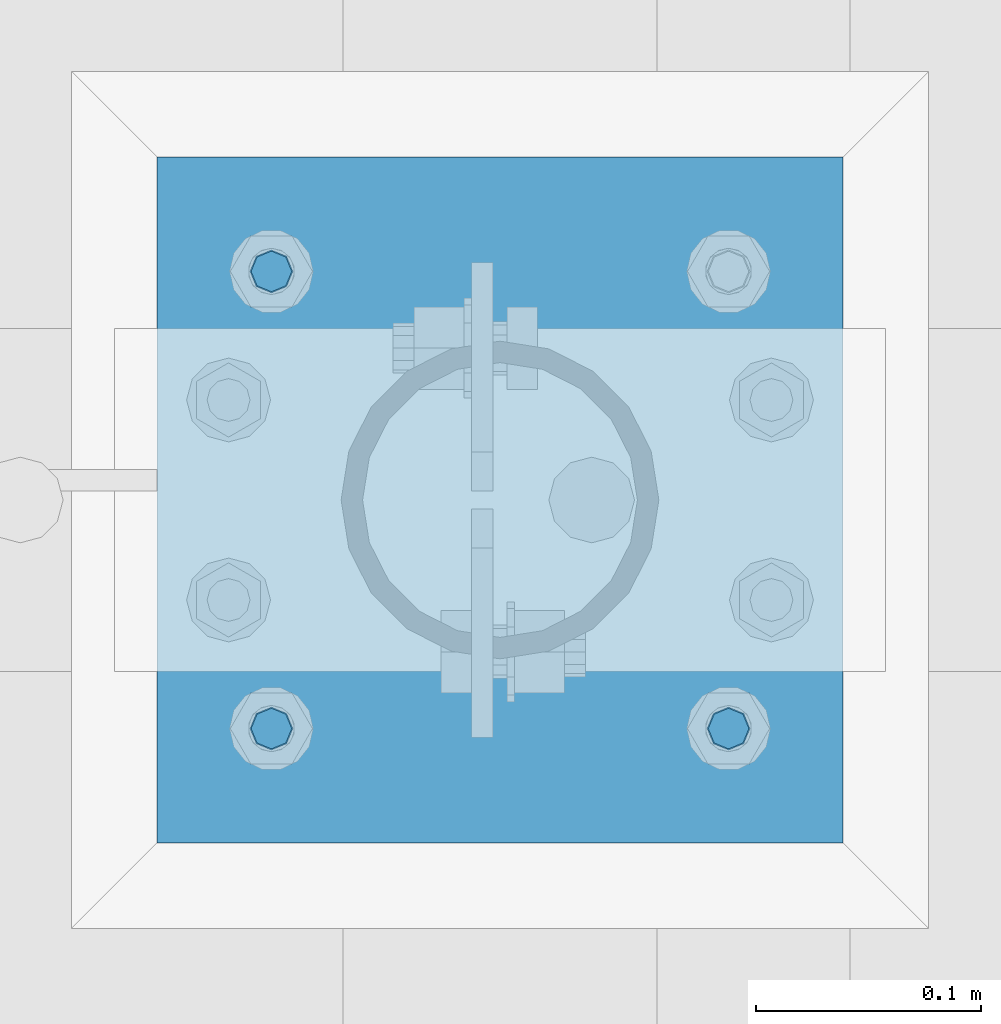
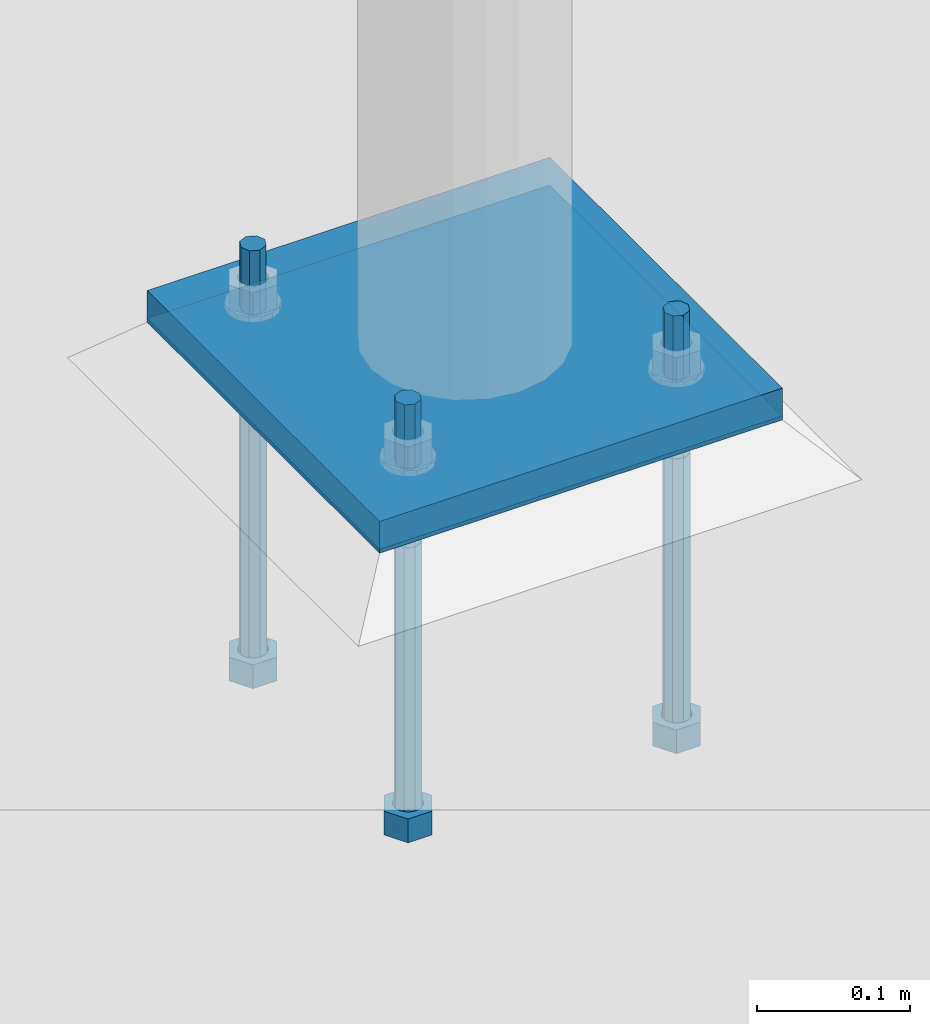
# One storey, part 399 of 975: 5 beams.
"""IFC2X3 building model written with IfcOpenShell, lengths in millimetres."""

from ifc_helpers import new_model, si_unit, frame, origin_with_axes, place, context, subcontext, project, spatial, faceted_brep, material, type_object, element, save


model = new_model("IFC2X3")

# Units and contexts
model_context = context("Model", 3, precision=1e-05, world=origin_with_axes())
body_context = subcontext(model_context, "Body", "Model", "MODEL_VIEW")
ifc_project = project(units=[si_unit("LENGTHUNIT", "METRE", prefix="MILLI"), si_unit("AREAUNIT", "SQUARE_METRE"), si_unit("VOLUMEUNIT", "CUBIC_METRE"), si_unit("MASSUNIT", "GRAM", prefix="KILO"), si_unit("TIMEUNIT", "SECOND"), si_unit("PLANEANGLEUNIT", "RADIAN"), si_unit("SOLIDANGLEUNIT", "STERADIAN"), si_unit("THERMODYNAMICTEMPERATUREUNIT", "DEGREE_CELSIUS"), si_unit("LUMINOUSINTENSITYUNIT", "LUMEN")], contexts=[model_context])

# Site, building, storey
site_placement = place(None, origin_with_axes())
site = spatial("IfcSite", under=ifc_project, at=site_placement, CompositionType="ELEMENT")
building_placement = place(site_placement, origin_with_axes())
building = spatial("IfcBuilding", under=site, at=building_placement, Name="Undefined", CompositionType="ELEMENT")
storey_placement = place(building_placement, origin_with_axes())
storey = spatial("IfcBuildingStorey", under=building, at=storey_placement, Name="Undefined", CompositionType="ELEMENT", Elevation=0.0)

# Beams
ifc_material_1 = material(Name="STEEL/F1554-36")
beam_type_1 = type_object("IfcBeamType", PredefinedType="NOTDEFINED")
beam_1_placement = place(storey_placement, frame((8128.00000152588, 13493.75, -304.799999999999), z_axis=(0.0, -1.0, 0.0), x_axis=(0.0, 0.0, -1.0)))
element("IfcBeam", 1, at=beam_1_placement, inside=storey, type_object=beam_type_1, material=ifc_material_1, Name="HEADED_ANCHOR_BOLT", context=body_context, shape_type="Brep", body=[
    faceted_brep([(210.34375, -9.13000011444637, 15.8100004196167), (210.34375, -18.2600002288873, 0.0), (229.393749999999, -18.2600002288873, 0.0), (229.393749999999, -9.13000011444637, 15.8100004196167), (210.34375, 9.13000011443546, 15.8100004196167), (229.393749999999, 9.13000011443546, 15.8100004196167), (210.34375, 18.2600002288764, 0.0), (229.393749999999, 18.2600002288764, 0.0), (210.34375, 9.13000011443546, -15.8100004196167), (229.393749999999, 9.13000011443546, -15.8100004196167), (210.34375, -9.13000011444637, -15.8100004196167), (229.393749999999, -9.13000011444637, -15.8100004196167), (210.34375, -4.47768005528815, 9.29799844179888), (210.34375, -8.06850066047991, 6.43441456490837), (210.34375, -10.0612557561972, 2.29641597052159), (210.34375, -10.0612557561972, -2.29641597052159), (210.34375, -8.06850066047991, -6.43441456490837), (210.34375, -4.47768005528815, -9.29799844179888), (210.34375, -5.45696821063757e-12, -10.3199996948242), (210.34375, 4.47768005527723, -9.29799844179888), (210.34375, 8.068500660469, -6.43441456490837), (210.34375, 10.0612557561863, -2.29641597052159), (210.34375, 10.0612557561863, 2.29641597052159), (210.34375, 8.068500660469, 6.43441456490837), (210.34375, 4.47768005527723, 9.29799844179888), (210.34375, -5.45696821063757e-12, 10.3199996948242), (229.393749999999, -5.45696821063757e-12, 10.3199996948242), (229.393749999999, -4.47768005528815, 9.29799844179888), (229.393749999999, -8.06850066047991, 6.43441456490837), (229.393749999999, -10.0612557561972, 2.29641597052159), (229.393749999999, -10.0612557561972, -2.29641597052159), (229.393749999999, -8.06850066047991, -6.43441456490837), (229.393749999999, -4.47768005528815, -9.29799844179888), (229.393749999999, -5.45696821063757e-12, -10.3199996948242), (229.393749999999, 4.47768005527723, -9.29799844179888), (229.393749999999, 8.068500660469, -6.43441456490837), (229.393749999999, 10.0612557561863, -2.29641597052159), (229.393749999999, 10.0612557561863, 2.29641597052159), (229.393749999999, 8.068500660469, 6.43441456490837), (229.393749999999, 4.47768005527723, 9.29799844179888), (0.0, -6.73519209080223, 6.73519209080186), (0.0, -9.52499999999964, 0.0), (228.6, -9.52500000000146, 0.0), (228.6, -6.73519209080405, 6.73519209080223), (-9.87109982941227e-13, -1.20792265079217e-13, 9.52499961853027), (228.6, 0.0, 9.52499999999964), (0.0, 6.73519209080223, 6.73519209080186), (228.6, 6.73519209080405, 6.73519209080223), (0.0, 9.52499999999964, 0.0), (228.6, 9.52500000000146, 0.0), (0.0, 6.73519209080223, -6.73519209080186), (228.6, 6.73519209080405, -6.73519209080223), (2.95075507493764e-12, -1.20792265079217e-13, -9.52499961853027), (228.6, 0.0, -9.52499999999964), (-114.293750057273, -6.36396001342564, 6.36396103067909), (-114.293749999997, 1.01725345302839e-06, 9.0), (-114.293749942721, 6.36396204793255, 6.36396103067909), (-114.293749918997, 9.00000101725345, 0.0), (-114.293749942721, 6.36396204793255, -6.36396103067909), (-114.293749999997, 1.01725345302839e-06, -9.0), (-114.293750057273, -6.36396001342564, -6.36396103067909), (-114.293750080997, -8.99999898274655, 0.0), (0.00625005727778216, 6.36396101919127, -6.36396103067909), (0.00625000000218279, -1.14878275780939e-08, -9.0), (0.00624994272658341, -6.36396104216692, -6.36396103067909), (0.00624991900230043, -9.00000001148783, 0.0), (0.00624994272658341, -6.36396104216692, 6.36396103067909), (0.00625000000218279, -1.14878275780939e-08, 9.0), (0.00625005727778216, 6.36396101919127, 6.36396103067909), (0.00625008100212199, 8.99999998851217, 0.0), (0.0, -6.73519209080223, -6.73519209080186), (228.6, -6.73519209080405, -6.73519209080223)], [[[0, 1, 2, 3]], [[4, 0, 3, 5]], [[6, 4, 5, 7]], [[8, 6, 7, 9]], [[10, 8, 9, 11]], [[0, 4, 6, 8, 10, 1], [12, 13, 14, 15, 16, 17, 18, 19, 20, 21, 22, 23, 24, 25]], [[12, 25, 26, 27]], [[13, 12, 27, 28]], [[14, 13, 28, 29]], [[15, 14, 29, 30]], [[16, 15, 30, 31]], [[17, 16, 31, 32]], [[18, 17, 32, 33]], [[19, 18, 33, 34]], [[20, 19, 34, 35]], [[21, 20, 35, 36]], [[22, 21, 36, 37]], [[23, 22, 37, 38]], [[24, 23, 38, 39]], [[25, 24, 39, 26]], [[9, 7, 5, 3, 2, 11], [38, 37, 36, 35, 34, 33, 32, 31, 30, 29, 28, 27, 26, 39]], [[1, 10, 11, 2]], [[40, 41, 42, 43]], [[44, 40, 43, 45]], [[46, 44, 45, 47]], [[48, 46, 47, 49]], [[50, 48, 49, 51]], [[52, 50, 51, 53]], [[54, 55, 56, 57, 58, 59, 60, 61]], [[59, 58, 62, 63]], [[60, 59, 63, 64]], [[61, 60, 64, 65]], [[54, 61, 65, 66]], [[55, 54, 66, 67]], [[56, 55, 67, 68]], [[57, 56, 68, 69]], [[58, 57, 69, 62]], [[40, 44, 46, 48, 50, 52, 70, 41], [68, 67, 66, 65, 64, 63, 62, 69]], [[41, 70, 71, 42]], [[53, 51, 49, 47, 45, 43, 42, 71]], [[70, 52, 53, 71]]]),
])
beam_2_placement = place(storey_placement, frame((8128.00000152588, 13290.5500030518, -304.799999999999), z_axis=(0.0, -1.0, 0.0), x_axis=(0.0, 0.0, -1.0)))
element("IfcBeam", 2, at=beam_2_placement, inside=storey, type_object=beam_type_1, material=ifc_material_1, Name="HEADED_ANCHOR_BOLT", context=body_context, shape_type="Brep", body=[
    faceted_brep([(210.34375, -9.13000011444637, 15.8100004196167), (210.34375, -18.2600002288873, 0.0), (229.393749999999, -18.2600002288873, 0.0), (229.393749999999, -9.13000011444637, 15.8100004196167), (210.34375, 9.13000011443546, 15.8100004196167), (229.393749999999, 9.13000011443546, 15.8100004196167), (210.34375, 18.2600002288764, 0.0), (229.393749999999, 18.2600002288764, 0.0), (210.34375, 9.13000011443546, -15.8100004196167), (229.393749999999, 9.13000011443546, -15.8100004196167), (210.34375, -9.13000011444637, -15.8100004196167), (229.393749999999, -9.13000011444637, -15.8100004196167), (210.34375, -4.47768005528815, 9.29799844179888), (210.34375, -8.06850066047991, 6.43441456490837), (210.34375, -10.0612557561972, 2.29641597052159), (210.34375, -10.0612557561972, -2.29641597052159), (210.34375, -8.06850066047991, -6.43441456490837), (210.34375, -4.47768005528815, -9.29799844179888), (210.34375, -5.45696821063757e-12, -10.3199996948242), (210.34375, 4.47768005527723, -9.29799844179888), (210.34375, 8.068500660469, -6.43441456490837), (210.34375, 10.0612557561863, -2.29641597052159), (210.34375, 10.0612557561863, 2.29641597052159), (210.34375, 8.068500660469, 6.43441456490837), (210.34375, 4.47768005527723, 9.29799844179888), (210.34375, -5.45696821063757e-12, 10.3199996948242), (229.393749999999, -5.45696821063757e-12, 10.3199996948242), (229.393749999999, -4.47768005528815, 9.29799844179888), (229.393749999999, -8.06850066047991, 6.43441456490837), (229.393749999999, -10.0612557561972, 2.29641597052159), (229.393749999999, -10.0612557561972, -2.29641597052159), (229.393749999999, -8.06850066047991, -6.43441456490837), (229.393749999999, -4.47768005528815, -9.29799844179888), (229.393749999999, -5.45696821063757e-12, -10.3199996948242), (229.393749999999, 4.47768005527723, -9.29799844179888), (229.393749999999, 8.068500660469, -6.43441456490837), (229.393749999999, 10.0612557561863, -2.29641597052159), (229.393749999999, 10.0612557561863, 2.29641597052159), (229.393749999999, 8.068500660469, 6.43441456490837), (229.393749999999, 4.47768005527723, 9.29799844179888), (0.0, -6.73519209080223, 6.73519209080186), (0.0, -9.52499999999964, 0.0), (228.6, -9.52500000000146, 0.0), (228.6, -6.73519209080405, 6.73519209080223), (-9.87109982941227e-13, -1.20792265079217e-13, 9.52499961853027), (228.6, 0.0, 9.52499999999964), (0.0, 6.73519209080223, 6.73519209080186), (228.6, 6.73519209080405, 6.73519209080223), (0.0, 9.52499999999964, 0.0), (228.6, 9.52500000000146, 0.0), (0.0, 6.73519209080223, -6.73519209080186), (228.6, 6.73519209080405, -6.73519209080223), (2.95075507493764e-12, -1.20792265079217e-13, -9.52499961853027), (228.6, 0.0, -9.52499999999964), (-114.293750057273, -6.36396001342564, 6.36396103067909), (-114.293749999997, 1.01725345302839e-06, 9.0), (-114.293749942721, 6.36396204793255, 6.36396103067909), (-114.293749918997, 9.00000101725345, 0.0), (-114.293749942721, 6.36396204793255, -6.36396103067909), (-114.293749999997, 1.01725345302839e-06, -9.0), (-114.293750057273, -6.36396001342564, -6.36396103067909), (-114.293750080997, -8.99999898274655, 0.0), (0.00625005727778216, 6.36396101919127, -6.36396103067909), (0.00625000000218279, -1.14878275780939e-08, -9.0), (0.00624994272658341, -6.36396104216692, -6.36396103067909), (0.00624991900230043, -9.00000001148783, 0.0), (0.00624994272658341, -6.36396104216692, 6.36396103067909), (0.00625000000218279, -1.14878275780939e-08, 9.0), (0.00625005727778216, 6.36396101919127, 6.36396103067909), (0.00625008100212199, 8.99999998851217, 0.0), (0.0, -6.73519209080223, -6.73519209080186), (228.6, -6.73519209080405, -6.73519209080223)], [[[0, 1, 2, 3]], [[4, 0, 3, 5]], [[6, 4, 5, 7]], [[8, 6, 7, 9]], [[10, 8, 9, 11]], [[0, 4, 6, 8, 10, 1], [12, 13, 14, 15, 16, 17, 18, 19, 20, 21, 22, 23, 24, 25]], [[12, 25, 26, 27]], [[13, 12, 27, 28]], [[14, 13, 28, 29]], [[15, 14, 29, 30]], [[16, 15, 30, 31]], [[17, 16, 31, 32]], [[18, 17, 32, 33]], [[19, 18, 33, 34]], [[20, 19, 34, 35]], [[21, 20, 35, 36]], [[22, 21, 36, 37]], [[23, 22, 37, 38]], [[24, 23, 38, 39]], [[25, 24, 39, 26]], [[9, 7, 5, 3, 2, 11], [38, 37, 36, 35, 34, 33, 32, 31, 30, 29, 28, 27, 26, 39]], [[1, 10, 11, 2]], [[40, 41, 42, 43]], [[44, 40, 43, 45]], [[46, 44, 45, 47]], [[48, 46, 47, 49]], [[50, 48, 49, 51]], [[52, 50, 51, 53]], [[54, 55, 56, 57, 58, 59, 60, 61]], [[59, 58, 62, 63]], [[60, 59, 63, 64]], [[61, 60, 64, 65]], [[54, 61, 65, 66]], [[55, 54, 66, 67]], [[56, 55, 67, 68]], [[57, 56, 68, 69]], [[58, 57, 69, 62]], [[40, 44, 46, 48, 50, 52, 70, 41], [68, 67, 66, 65, 64, 63, 62, 69]], [[41, 70, 71, 42]], [[53, 51, 49, 47, 45, 43, 42, 71]], [[70, 52, 53, 71]]]),
])
beam_3_placement = place(storey_placement, frame((8331.19999847412, 13290.5500030518, -304.799999999999), z_axis=(0.0, -1.0, 0.0), x_axis=(0.0, 0.0, -1.0)))
element("IfcBeam", 3, at=beam_3_placement, inside=storey, type_object=beam_type_1, material=ifc_material_1, Name="HEADED_ANCHOR_BOLT", context=body_context, shape_type="Brep", body=[
    faceted_brep([(210.34375, -9.13000011444637, 15.8100004196167), (210.34375, -18.2600002288873, 0.0), (229.393749999999, -18.2600002288873, 0.0), (229.393749999999, -9.13000011444637, 15.8100004196167), (210.34375, 9.13000011443546, 15.8100004196167), (229.393749999999, 9.13000011443546, 15.8100004196167), (210.34375, 18.2600002288764, 0.0), (229.393749999999, 18.2600002288764, 0.0), (210.34375, 9.13000011443546, -15.8100004196167), (229.393749999999, 9.13000011443546, -15.8100004196167), (210.34375, -9.13000011444637, -15.8100004196167), (229.393749999999, -9.13000011444637, -15.8100004196167), (210.34375, -4.47768005528815, 9.29799844179888), (210.34375, -8.06850066047991, 6.43441456490837), (210.34375, -10.0612557561972, 2.29641597052159), (210.34375, -10.0612557561972, -2.29641597052159), (210.34375, -8.06850066047991, -6.43441456490837), (210.34375, -4.47768005528815, -9.29799844179888), (210.34375, -5.45696821063757e-12, -10.3199996948242), (210.34375, 4.47768005527723, -9.29799844179888), (210.34375, 8.068500660469, -6.43441456490837), (210.34375, 10.0612557561863, -2.29641597052159), (210.34375, 10.0612557561863, 2.29641597052159), (210.34375, 8.068500660469, 6.43441456490837), (210.34375, 4.47768005527723, 9.29799844179888), (210.34375, -5.45696821063757e-12, 10.3199996948242), (229.393749999999, -5.45696821063757e-12, 10.3199996948242), (229.393749999999, -4.47768005528815, 9.29799844179888), (229.393749999999, -8.06850066047991, 6.43441456490837), (229.393749999999, -10.0612557561972, 2.29641597052159), (229.393749999999, -10.0612557561972, -2.29641597052159), (229.393749999999, -8.06850066047991, -6.43441456490837), (229.393749999999, -4.47768005528815, -9.29799844179888), (229.393749999999, -5.45696821063757e-12, -10.3199996948242), (229.393749999999, 4.47768005527723, -9.29799844179888), (229.393749999999, 8.068500660469, -6.43441456490837), (229.393749999999, 10.0612557561863, -2.29641597052159), (229.393749999999, 10.0612557561863, 2.29641597052159), (229.393749999999, 8.068500660469, 6.43441456490837), (229.393749999999, 4.47768005527723, 9.29799844179888), (0.0, -6.73519209080223, 6.73519209080186), (0.0, -9.52499999999964, 0.0), (228.6, -9.52500000000146, 0.0), (228.6, -6.73519209080405, 6.73519209080223), (-9.87109982941227e-13, -1.20792265079217e-13, 9.52499961853027), (228.6, 0.0, 9.52499999999964), (0.0, 6.73519209080223, 6.73519209080186), (228.6, 6.73519209080405, 6.73519209080223), (0.0, 9.52499999999964, 0.0), (228.6, 9.52500000000146, 0.0), (0.0, 6.73519209080223, -6.73519209080186), (228.6, 6.73519209080405, -6.73519209080223), (2.95075507493764e-12, -1.20792265079217e-13, -9.52499961853027), (228.6, 0.0, -9.52499999999964), (-114.293750057273, -6.36396001342564, 6.36396103067909), (-114.293749999997, 1.01725345302839e-06, 9.0), (-114.293749942721, 6.36396204793255, 6.36396103067909), (-114.293749918997, 9.00000101725345, 0.0), (-114.293749942721, 6.36396204793255, -6.36396103067909), (-114.293749999997, 1.01725345302839e-06, -9.0), (-114.293750057273, -6.36396001342564, -6.36396103067909), (-114.293750080997, -8.99999898274655, 0.0), (0.00625005727778216, 6.36396101919127, -6.36396103067909), (0.00625000000218279, -1.14878275780939e-08, -9.0), (0.00624994272658341, -6.36396104216692, -6.36396103067909), (0.00624991900230043, -9.00000001148783, 0.0), (0.00624994272658341, -6.36396104216692, 6.36396103067909), (0.00625000000218279, -1.14878275780939e-08, 9.0), (0.00625005727778216, 6.36396101919127, 6.36396103067909), (0.00625008100212199, 8.99999998851217, 0.0), (0.0, -6.73519209080223, -6.73519209080186), (228.6, -6.73519209080405, -6.73519209080223)], [[[0, 1, 2, 3]], [[4, 0, 3, 5]], [[6, 4, 5, 7]], [[8, 6, 7, 9]], [[10, 8, 9, 11]], [[0, 4, 6, 8, 10, 1], [12, 13, 14, 15, 16, 17, 18, 19, 20, 21, 22, 23, 24, 25]], [[12, 25, 26, 27]], [[13, 12, 27, 28]], [[14, 13, 28, 29]], [[15, 14, 29, 30]], [[16, 15, 30, 31]], [[17, 16, 31, 32]], [[18, 17, 32, 33]], [[19, 18, 33, 34]], [[20, 19, 34, 35]], [[21, 20, 35, 36]], [[22, 21, 36, 37]], [[23, 22, 37, 38]], [[24, 23, 38, 39]], [[25, 24, 39, 26]], [[9, 7, 5, 3, 2, 11], [38, 37, 36, 35, 34, 33, 32, 31, 30, 29, 28, 27, 26, 39]], [[1, 10, 11, 2]], [[40, 41, 42, 43]], [[44, 40, 43, 45]], [[46, 44, 45, 47]], [[48, 46, 47, 49]], [[50, 48, 49, 51]], [[52, 50, 51, 53]], [[54, 55, 56, 57, 58, 59, 60, 61]], [[59, 58, 62, 63]], [[60, 59, 63, 64]], [[61, 60, 64, 65]], [[54, 61, 65, 66]], [[55, 54, 66, 67]], [[56, 55, 67, 68]], [[57, 56, 68, 69]], [[58, 57, 69, 62]], [[40, 44, 46, 48, 50, 52, 70, 41], [68, 67, 66, 65, 64, 63, 62, 69]], [[41, 70, 71, 42]], [[53, 51, 49, 47, 45, 43, 42, 71]], [[70, 52, 53, 71]]]),
])
ifc_material_2 = material(Name="STEEL/A36")
beam_type_2 = type_object("IfcBeamType", PredefinedType="NOTDEFINED")
beam_4_placement = place(storey_placement, frame((8229.6, 13239.75, -265.112500000001), z_axis=(-0.999999999999998, 6.90000001668524e-08, 0.0), x_axis=(0.0, 1.0, 0.0)))
element("IfcBeam", 4, at=beam_4_placement, inside=storey, type_object=beam_type_2, material=ifc_material_2, Name="TEMPLATE", context=body_context, shape_type="Brep", body=[
    faceted_brep([(0.0, 1.58750000000009, -152.4), (0.0, 1.58750000000009, 152.4), (304.799999999153, 1.58750000000001, 152.400000000001), (304.799999999153, 1.58750000000001, -152.400000000001), (0.0, -1.58750000000009, 152.4), (304.799999999153, -1.58750000000001, 152.400000000001), (0.0, -1.58750000000009, -152.4), (304.799999999153, -1.58750000000001, -152.400000000001)], [[[0, 1, 2, 3]], [[1, 4, 5, 2]], [[4, 6, 7, 5]], [[6, 0, 3, 7]], [[5, 7, 3, 2]], [[6, 4, 1, 0]]]),
])
beam_type_3 = type_object("IfcBeamType", PredefinedType="NOTDEFINED")
beam_5_placement = place(storey_placement, frame((8229.6, 13239.75, -254.0), z_axis=(-0.999999999999998, 6.90000001668524e-08, 0.0), x_axis=(0.0, 1.0, 0.0)))
element("IfcBeam", 5, at=beam_5_placement, inside=storey, type_object=beam_type_3, material=ifc_material_2, Name="PLATE", context=body_context, shape_type="Brep", body=[
    faceted_brep([(0.0, 12.7, -152.400000000001), (-1.36424205265939e-12, 12.7, 152.400009155273), (304.800000000003, 12.7, 152.400000000001), (304.800000000003, 12.7, -152.400000000001), (0.0, -12.7, 152.400000000001), (304.800000000003, -12.7, 152.400000000001), (0.0, -12.7, -152.400000000001), (304.800000000003, -12.7, -152.400000000001)], [[[0, 1, 2, 3]], [[1, 4, 5, 2]], [[4, 6, 7, 5]], [[6, 0, 3, 7]], [[5, 7, 3, 2]], [[6, 4, 1, 0]]]),
])

save(model, "model.ifc")
